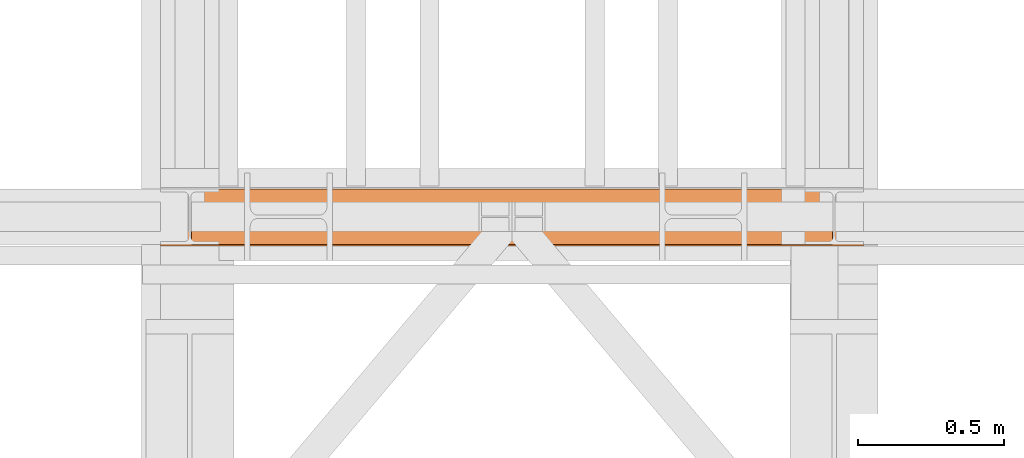
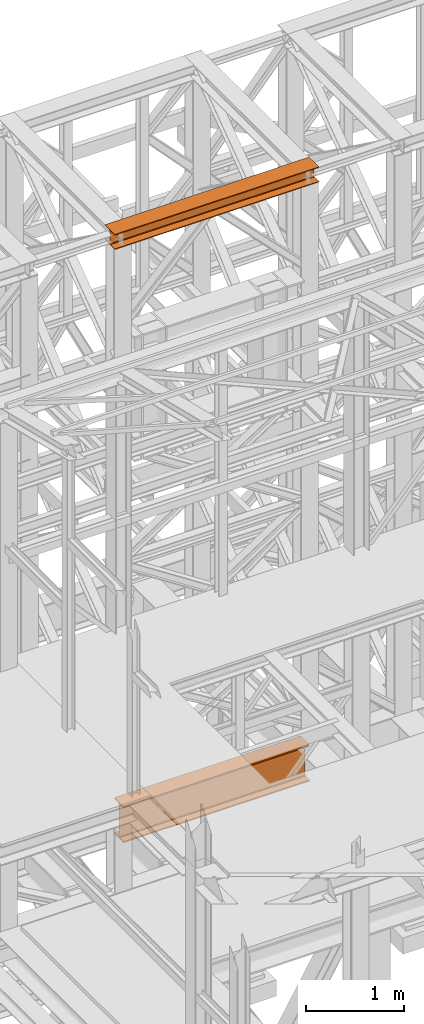
# One storey, part 145 of 208: 2 proxies.
"""IFC2X3 building model written with IfcOpenShell, lengths in millimetres."""

from ifc_helpers import new_model, entity, si_unit, converted_unit, frame, origin, origin_with_axes, place, context, subcontext, project, spatial, faceted_brep, element, save


model = new_model("IFC2X3")

# Units and contexts
model_context = context("Model", 3, precision=1e-05, world=origin())
plan_context = context("Plan", 3, precision=1e-05, world=origin())
body_context = subcontext(model_context, "Body", "Model", "MODEL_VIEW")
ifc_project = project(units=[si_unit("LENGTHUNIT", "METRE", prefix="MILLI"), converted_unit("PLANEANGLEUNIT", "DEGREE", entity("IfcPlaneAngleMeasure", 0.0174532925199433), si_unit("PLANEANGLEUNIT", "RADIAN"), dimensions=[0, 0, 0, 0, 0, 0, 0]), si_unit("AREAUNIT", "SQUARE_METRE"), si_unit("VOLUMEUNIT", "CUBIC_METRE")], contexts=[model_context, plan_context])

# Building, storey
building_placement = place(None, origin())
building = spatial("IfcBuilding", under=ifc_project, at=building_placement, CompositionType="COMPLEX")
storey_placement = place(building_placement, origin_with_axes())
storey = spatial("IfcBuildingStorey", under=building, at=storey_placement, Name="Geschoss", CompositionType="ELEMENT")

# Proxies
proxy_1_placement = place(storey_placement, frame((3299.254968580828, -16057.57439657637, 4834.989987483023), z_axis=(0.0, 0.0, 1.0), x_axis=(1.0, 0.0, 0.0)))
element("IfcBuildingElementProxy", 1, at=proxy_1_placement, inside=storey, context=body_context, shape_type="Brep", body=[
    faceted_brep([(2188.009999895692, 0.01000000000021828, 450.0100178813937), (2188.009999895692, 190.0100125169756, 450.0100178813937), (2188.009999895692, 190.0100125169756, 435.4100240564349), (2188.009999895692, 120.7100073045494, 435.4100091552737), (2188.009999895692, 109.841562265754, 433.2347078418734), (2188.009999895692, 101.8853126263621, 425.2784563398363), (2188.009999895692, 99.71000619068764, 414.4100113010409), (2188.009999895692, 99.71000619068764, 35.60999167919181), (2188.009999895692, 101.8853126263621, 24.74154664039634), (2188.009999895692, 109.841562265754, 16.78529513835929), (2188.009999895692, 120.7100073045494, 14.60999382495902), (2188.009999895692, 190.0100125169756, 14.60999382495902), (2188.009999895692, 190.0100125169756, 0.01000000000021828), (2188.009999895692, 0.01000000000021828, 0.01000000000021828), (2188.009999895692, 0.01000000000021828, 14.60999382495902), (2188.009999895692, 69.3100052124264, 14.60999382495902), (2188.009999895692, 80.17845025122188, 16.78529513835929), (2188.009999895692, 88.13469989061377, 24.74154664039634), (2188.009999895692, 90.3100063262882, 35.60999167919181), (2188.009999895692, 90.3100063262882, 414.4100113010409), (2188.009999895692, 88.13469989061377, 425.2784563398363), (2188.009999895692, 80.17845025122188, 433.2347078418734), (2188.009999895692, 69.3100052124264, 435.4100091552737), (2188.009999895692, 0.01000000000021828, 435.4100240564349), (2188.009999895692, 190.0100125169756, 450.0100178813937), (2188.009999895692, 0.01000000000021828, 450.0100178813937), (0.01000000000021828, 0.01000000000021828, 450.0100178813937), (0.01000000000021828, 190.0100125169756, 450.0100178813937), (2188.009999895692, 190.0100125169756, 435.4100240564349), (2188.009999895692, 190.0100125169756, 450.0100178813937), (0.01000000000021828, 190.0100125169756, 450.0100178813937), (0.01000000000021828, 190.0100125169756, 435.4100240564349), (2188.009999895692, 120.7100073045494, 435.4100091552737), (2188.009999895692, 190.0100125169756, 435.4100240564349), (0.01000000000021828, 190.0100125169756, 435.4100240564349), (0.01000000000021828, 120.7100073045494, 435.4100091552737), (2188.009999895692, 109.841562265754, 433.2347078418734), (2188.009999895692, 120.7100073045494, 435.4100091552737), (0.01000000000021828, 120.7100073045494, 435.4100091552737), (0.01000000000021828, 109.841562265754, 433.2347078418734), (2188.009999895692, 101.8853126263621, 425.2784563398363), (2188.009999895692, 109.841562265754, 433.2347078418734), (0.01000000000021828, 109.841562265754, 433.2347078418734), (0.01000000000021828, 101.8853126263621, 425.2784563398363), (2188.009999895692, 99.71000619068764, 414.4100113010409), (2188.009999895692, 101.8853126263621, 425.2784563398363), (0.01000000000021828, 101.8853126263621, 425.2784563398363), (0.01000000000021828, 99.71000619068764, 414.4100113010409), (2188.009999895692, 99.71000619068764, 35.60999167919181), (2188.009999895692, 99.71000619068764, 414.4100113010409), (0.01000000000021828, 99.71000619068764, 414.4100113010409), (0.01000000000021828, 99.71000619068764, 35.60999167919181), (2188.009999895692, 101.8853126263621, 24.74154664039634), (2188.009999895692, 99.71000619068764, 35.60999167919181), (0.01000000000021828, 99.71000619068764, 35.60999167919181), (0.01000000000021828, 101.8853126263621, 24.74154664039634), (2188.009999895692, 109.841562265754, 16.78529513835929), (2188.009999895692, 101.8853126263621, 24.74154664039634), (0.01000000000021828, 101.8853126263621, 24.74154664039634), (0.01000000000021828, 109.841562265754, 16.78529513835929), (2188.009999895692, 120.7100073045494, 14.60999382495902), (2188.009999895692, 109.841562265754, 16.78529513835929), (0.01000000000021828, 109.841562265754, 16.78529513835929), (0.01000000000021828, 120.7100073045494, 14.60999382495902), (2188.009999895692, 190.0100125169756, 14.60999382495902), (2188.009999895692, 120.7100073045494, 14.60999382495902), (0.01000000000021828, 120.7100073045494, 14.60999382495902), (0.01000000000021828, 190.0100125169756, 14.60999382495902), (2188.009999895692, 190.0100125169756, 0.01000000000021828), (2188.009999895692, 190.0100125169756, 14.60999382495902), (0.01000000000021828, 190.0100125169756, 14.60999382495902), (0.01000000000021828, 190.0100125169756, 0.01000000000021828), (2188.009999895692, 0.01000000000021828, 0.01000000000021828), (2188.009999895692, 190.0100125169756, 0.01000000000021828), (0.01000000000021828, 190.0100125169756, 0.01000000000021828), (0.01000000000021828, 0.01000000000021828, 0.01000000000021828), (2188.009999895692, 0.01000000000021828, 14.60999382495902), (2188.009999895692, 0.01000000000021828, 0.01000000000021828), (0.01000000000021828, 0.01000000000021828, 0.01000000000021828), (0.01000000000021828, 0.01000000000021828, 14.60999382495902), (2188.009999895692, 69.3100052124264, 14.60999382495902), (2188.009999895692, 0.01000000000021828, 14.60999382495902), (0.01000000000021828, 0.01000000000021828, 14.60999382495902), (0.01000000000021828, 69.3100052124264, 14.60999382495902), (2188.009999895692, 80.17845025122188, 16.78529513835929), (2188.009999895692, 69.3100052124264, 14.60999382495902), (0.01000000000021828, 69.3100052124264, 14.60999382495902), (0.01000000000021828, 80.17845025122188, 16.78529513835929), (2188.009999895692, 88.13469989061377, 24.74154664039634), (2188.009999895692, 80.17845025122188, 16.78529513835929), (0.01000000000021828, 80.17845025122188, 16.78529513835929), (0.01000000000021828, 88.13469989061377, 24.74154664039634), (2188.009999895692, 90.3100063262882, 35.60999167919181), (2188.009999895692, 88.13469989061377, 24.74154664039634), (0.01000000000021828, 88.13469989061377, 24.74154664039634), (0.01000000000021828, 90.3100063262882, 35.60999167919181), (2188.009999895692, 90.3100063262882, 414.4100113010409), (2188.009999895692, 90.3100063262882, 35.60999167919181), (0.01000000000021828, 90.3100063262882, 35.60999167919181), (0.01000000000021828, 90.3100063262882, 414.4100113010409), (2188.009999895692, 88.13469989061377, 425.2784563398363), (2188.009999895692, 90.3100063262882, 414.4100113010409), (0.01000000000021828, 90.3100063262882, 414.4100113010409), (0.01000000000021828, 88.13469989061377, 425.2784563398363), (2188.009999895692, 80.17845025122188, 433.2347078418734), (2188.009999895692, 88.13469989061377, 425.2784563398363), (0.01000000000021828, 88.13469989061377, 425.2784563398363), (0.01000000000021828, 80.17845025122188, 433.2347078418734), (2188.009999895692, 69.3100052124264, 435.4100091552737), (2188.009999895692, 80.17845025122188, 433.2347078418734), (0.01000000000021828, 80.17845025122188, 433.2347078418734), (0.01000000000021828, 69.3100052124264, 435.4100091552737), (2188.009999895692, 0.01000000000021828, 435.4100240564349), (2188.009999895692, 69.3100052124264, 435.4100091552737), (0.01000000000021828, 69.3100052124264, 435.4100091552737), (0.01000000000021828, 0.01000000000021828, 435.4100240564349), (2188.009999895692, 0.01000000000021828, 450.0100178813937), (2188.009999895692, 0.01000000000021828, 435.4100240564349), (0.01000000000021828, 0.01000000000021828, 435.4100240564349), (0.01000000000021828, 0.01000000000021828, 450.0100178813937), (0.01000000000021828, 0.01000000000021828, 450.0100178813937), (0.01000000000021828, 0.01000000000021828, 435.4100240564349), (0.01000000000021828, 69.3100052124264, 435.4100091552737), (0.01000000000021828, 80.17845025122188, 433.2347078418734), (0.01000000000021828, 88.13469989061377, 425.2784563398363), (0.01000000000021828, 90.3100063262882, 414.4100113010409), (0.01000000000021828, 90.3100063262882, 35.60999167919181), (0.01000000000021828, 88.13469989061377, 24.74154664039634), (0.01000000000021828, 80.17845025122188, 16.78529513835929), (0.01000000000021828, 69.3100052124264, 14.60999382495902), (0.01000000000021828, 0.01000000000021828, 14.60999382495902), (0.01000000000021828, 0.01000000000021828, 0.01000000000021828), (0.01000000000021828, 190.0100125169756, 0.01000000000021828), (0.01000000000021828, 190.0100125169756, 14.60999382495902), (0.01000000000021828, 120.7100073045494, 14.60999382495902), (0.01000000000021828, 109.841562265754, 16.78529513835929), (0.01000000000021828, 101.8853126263621, 24.74154664039634), (0.01000000000021828, 99.71000619068764, 35.60999167919181), (0.01000000000021828, 99.71000619068764, 414.4100113010409), (0.01000000000021828, 101.8853126263621, 425.2784563398363), (0.01000000000021828, 109.841562265754, 433.2347078418734), (0.01000000000021828, 120.7100073045494, 435.4100091552737), (0.01000000000021828, 190.0100125169756, 435.4100240564349), (0.01000000000021828, 190.0100125169756, 450.0100178813937)], [[[0, 1, 2, 3, 4, 5, 6, 7, 8, 9, 10, 11, 12, 13, 14, 15, 16, 17, 18, 19, 20, 21, 22, 23]], [[24, 25, 26, 27]], [[28, 29, 30, 31]], [[32, 33, 34, 35]], [[36, 37, 38, 39]], [[40, 41, 42, 43]], [[44, 45, 46, 47]], [[48, 49, 50, 51]], [[52, 53, 54, 55]], [[56, 57, 58, 59]], [[60, 61, 62, 63]], [[64, 65, 66, 67]], [[68, 69, 70, 71]], [[72, 73, 74, 75]], [[76, 77, 78, 79]], [[80, 81, 82, 83]], [[84, 85, 86, 87]], [[88, 89, 90, 91]], [[92, 93, 94, 95]], [[96, 97, 98, 99]], [[100, 101, 102, 103]], [[104, 105, 106, 107]], [[108, 109, 110, 111]], [[112, 113, 114, 115]], [[116, 117, 118, 119]], [[120, 121, 122, 123, 124, 125, 126, 127, 128, 129, 130, 131, 132, 133, 134, 135, 136, 137, 138, 139, 140, 141, 142, 143]]], orient=[[False], [False], [False], [False], [False], [False], [False], [False], [False], [False], [False], [False], [False], [False], [False], [False], [False], [False], [False], [False], [False], [False], [False], [False], [False], [False]]),
])
proxy_2_placement = place(storey_placement, frame((3193.254967038549, -16062.574391808, 12249.99005869381), z_axis=(0.0, 0.0, 1.0), x_axis=(1.0, 0.0, 0.0)))
element("IfcBuildingElementProxy", 2, at=proxy_2_placement, inside=storey, context=body_context, shape_type="Brep", body=[
    faceted_brep([(0.01000000000021828, 0.01000000000021828, 0.01000000000021828), (0.01000000000021828, 200.0100029802325, 0.01000000000021828), (0.01000000000021828, 200.0100029802325, 10.00999791383765), (0.01000000000021828, 121.2600035762789, 10.01000536441825), (0.01000000000021828, 111.9441915473344, 11.87455041170142), (0.01000000000021828, 105.1245498640838, 18.69419349193595), (0.01000000000021828, 103.2600015571716, 28.01000458955787), (0.01000000000021828, 103.2600015571716, 162.0100153779986), (0.01000000000021828, 105.1245498640838, 171.3258264756205), (0.01000000000021828, 111.9441915473344, 178.145469555855), (0.01000000000021828, 121.2600035762789, 180.0100146031382), (0.01000000000021828, 200.0100029802325, 180.0100146031382), (0.01000000000021828, 200.0100029802325, 190.0100125169756), (0.01000000000021828, 0.01000000000021828, 190.0100125169756), (0.01000000000021828, 0.01000000000021828, 180.0100146031382), (0.01000000000021828, 78.75999940395377, 180.0100146031382), (0.01000000000021828, 88.07581143289826, 178.145469555855), (0.01000000000021828, 94.89545311614893, 171.3258264756205), (0.01000000000021828, 96.76000142306111, 162.0100153779986), (0.01000000000021828, 96.76000142306111, 28.01000458955787), (0.01000000000021828, 94.89545311614893, 18.69419349193595), (0.01000000000021828, 88.07581143289826, 11.87455041170142), (0.01000000000021828, 78.75999940395377, 10.01000536441825), (0.01000000000021828, 0.01000000000021828, 10.00999791383765), (0.01000000000021828, 200.0100029802325, 0.01000000000021828), (0.01000000000021828, 0.01000000000021828, 0.01000000000021828), (2400.010002980233, 0.01000000000021828, 0.01000000000021828), (2400.010002980233, 200.0100029802325, 0.01000000000021828), (0.01000000000021828, 200.0100029802325, 10.00999791383765), (0.01000000000021828, 200.0100029802325, 0.01000000000021828), (2400.010002980233, 200.0100029802325, 0.01000000000021828), (2400.010002980233, 200.0100029802325, 10.00999791383765), (0.01000000000021828, 121.2600035762789, 10.01000536441825), (0.01000000000021828, 200.0100029802325, 10.00999791383765), (2400.010002980233, 200.0100029802325, 10.00999791383765), (2400.010002980233, 121.2600035762789, 10.01000536441825), (0.01000000000021828, 111.9441915473344, 11.87455041170142), (0.01000000000021828, 121.2600035762789, 10.01000536441825), (2400.010002980233, 121.2600035762789, 10.01000536441825), (2400.010002980233, 111.9441915473344, 11.87455041170142), (0.01000000000021828, 105.1245498640838, 18.69419349193595), (0.01000000000021828, 111.9441915473344, 11.87455041170142), (2400.010002980233, 111.9441915473344, 11.87455041170142), (2400.010002980233, 105.1245498640838, 18.69419349193595), (0.01000000000021828, 103.2600015571716, 28.01000458955787), (0.01000000000021828, 105.1245498640838, 18.69419349193595), (2400.010002980233, 105.1245498640838, 18.69419349193595), (2400.010002980233, 103.2600015571716, 28.01000458955787), (0.01000000000021828, 103.2600015571716, 162.0100153779986), (0.01000000000021828, 103.2600015571716, 28.01000458955787), (2400.010002980233, 103.2600015571716, 28.01000458955787), (2400.010002980233, 103.2600015571716, 162.0100153779986), (0.01000000000021828, 105.1245498640838, 171.3258264756205), (0.01000000000021828, 103.2600015571716, 162.0100153779986), (2400.010002980233, 103.2600015571716, 162.0100153779986), (2400.010002980233, 105.1245498640838, 171.3258264756205), (0.01000000000021828, 111.9441915473344, 178.145469555855), (0.01000000000021828, 105.1245498640838, 171.3258264756205), (2400.010002980233, 105.1245498640838, 171.3258264756205), (2400.010002980233, 111.9441915473344, 178.145469555855), (0.01000000000021828, 121.2600035762789, 180.0100146031382), (0.01000000000021828, 111.9441915473344, 178.145469555855), (2400.010002980233, 111.9441915473344, 178.145469555855), (2400.010002980233, 121.2600035762789, 180.0100146031382), (0.01000000000021828, 200.0100029802325, 180.0100146031382), (0.01000000000021828, 121.2600035762789, 180.0100146031382), (2400.010002980233, 121.2600035762789, 180.0100146031382), (2400.010002980233, 200.0100029802325, 180.0100146031382), (0.01000000000021828, 200.0100029802325, 190.0100125169756), (0.01000000000021828, 200.0100029802325, 180.0100146031382), (2400.010002980233, 200.0100029802325, 180.0100146031382), (2400.010002980233, 200.0100029802325, 190.0100125169756), (0.01000000000021828, 0.01000000000021828, 190.0100125169756), (0.01000000000021828, 200.0100029802325, 190.0100125169756), (2400.010002980233, 200.0100029802325, 190.0100125169756), (2400.010002980233, 0.01000000000021828, 190.0100125169756), (0.01000000000021828, 0.01000000000021828, 180.0100146031382), (0.01000000000021828, 0.01000000000021828, 190.0100125169756), (2400.010002980233, 0.01000000000021828, 190.0100125169756), (2400.010002980233, 0.01000000000021828, 180.0100146031382), (0.01000000000021828, 78.75999940395377, 180.0100146031382), (0.01000000000021828, 0.01000000000021828, 180.0100146031382), (2400.010002980233, 0.01000000000021828, 180.0100146031382), (2400.010002980233, 78.75999940395377, 180.0100146031382), (0.01000000000021828, 88.07581143289826, 178.145469555855), (0.01000000000021828, 78.75999940395377, 180.0100146031382), (2400.010002980233, 78.75999940395377, 180.0100146031382), (2400.010002980233, 88.07581143289826, 178.145469555855), (0.01000000000021828, 94.89545311614893, 171.3258264756205), (0.01000000000021828, 88.07581143289826, 178.145469555855), (2400.010002980233, 88.07581143289826, 178.145469555855), (2400.010002980233, 94.89545311614893, 171.3258264756205), (0.01000000000021828, 96.76000142306111, 162.0100153779986), (0.01000000000021828, 94.89545311614893, 171.3258264756205), (2400.010002980233, 94.89545311614893, 171.3258264756205), (2400.010002980233, 96.76000142306111, 162.0100153779986), (0.01000000000021828, 96.76000142306111, 28.01000458955787), (0.01000000000021828, 96.76000142306111, 162.0100153779986), (2400.010002980233, 96.76000142306111, 162.0100153779986), (2400.010002980233, 96.76000142306111, 28.01000458955787), (0.01000000000021828, 94.89545311614893, 18.69419349193595), (0.01000000000021828, 96.76000142306111, 28.01000458955787), (2400.010002980233, 96.76000142306111, 28.01000458955787), (2400.010002980233, 94.89545311614893, 18.69419349193595), (0.01000000000021828, 88.07581143289826, 11.87455041170142), (0.01000000000021828, 94.89545311614893, 18.69419349193595), (2400.010002980233, 94.89545311614893, 18.69419349193595), (2400.010002980233, 88.07581143289826, 11.87455041170142), (0.01000000000021828, 78.75999940395377, 10.01000536441825), (0.01000000000021828, 88.07581143289826, 11.87455041170142), (2400.010002980233, 88.07581143289826, 11.87455041170142), (2400.010002980233, 78.75999940395377, 10.01000536441825), (0.01000000000021828, 0.01000000000021828, 10.00999791383765), (0.01000000000021828, 78.75999940395377, 10.01000536441825), (2400.010002980233, 78.75999940395377, 10.01000536441825), (2400.010002980233, 0.01000000000021828, 10.00999791383765), (0.01000000000021828, 0.01000000000021828, 0.01000000000021828), (0.01000000000021828, 0.01000000000021828, 10.00999791383765), (2400.010002980233, 0.01000000000021828, 10.00999791383765), (2400.010002980233, 0.01000000000021828, 0.01000000000021828), (2400.010002980233, 0.01000000000021828, 0.01000000000021828), (2400.010002980233, 0.01000000000021828, 10.00999791383765), (2400.010002980233, 78.75999940395377, 10.01000536441825), (2400.010002980233, 88.07581143289826, 11.87455041170142), (2400.010002980233, 94.89545311614893, 18.69419349193595), (2400.010002980233, 96.76000142306111, 28.01000458955787), (2400.010002980233, 96.76000142306111, 162.0100153779986), (2400.010002980233, 94.89545311614893, 171.3258264756205), (2400.010002980233, 88.07581143289826, 178.145469555855), (2400.010002980233, 78.75999940395377, 180.0100146031382), (2400.010002980233, 0.01000000000021828, 180.0100146031382), (2400.010002980233, 0.01000000000021828, 190.0100125169756), (2400.010002980233, 200.0100029802325, 190.0100125169756), (2400.010002980233, 200.0100029802325, 180.0100146031382), (2400.010002980233, 121.2600035762789, 180.0100146031382), (2400.010002980233, 111.9441915473344, 178.145469555855), (2400.010002980233, 105.1245498640838, 171.3258264756205), (2400.010002980233, 103.2600015571716, 162.0100153779986), (2400.010002980233, 103.2600015571716, 28.01000458955787), (2400.010002980233, 105.1245498640838, 18.69419349193595), (2400.010002980233, 111.9441915473344, 11.87455041170142), (2400.010002980233, 121.2600035762789, 10.01000536441825), (2400.010002980233, 200.0100029802325, 10.00999791383765), (2400.010002980233, 200.0100029802325, 0.01000000000021828)], [[[0, 1, 2, 3, 4, 5, 6, 7, 8, 9, 10, 11, 12, 13, 14, 15, 16, 17, 18, 19, 20, 21, 22, 23]], [[24, 25, 26, 27]], [[28, 29, 30, 31]], [[32, 33, 34, 35]], [[36, 37, 38, 39]], [[40, 41, 42, 43]], [[44, 45, 46, 47]], [[48, 49, 50, 51]], [[52, 53, 54, 55]], [[56, 57, 58, 59]], [[60, 61, 62, 63]], [[64, 65, 66, 67]], [[68, 69, 70, 71]], [[72, 73, 74, 75]], [[76, 77, 78, 79]], [[80, 81, 82, 83]], [[84, 85, 86, 87]], [[88, 89, 90, 91]], [[92, 93, 94, 95]], [[96, 97, 98, 99]], [[100, 101, 102, 103]], [[104, 105, 106, 107]], [[108, 109, 110, 111]], [[112, 113, 114, 115]], [[116, 117, 118, 119]], [[120, 121, 122, 123, 124, 125, 126, 127, 128, 129, 130, 131, 132, 133, 134, 135, 136, 137, 138, 139, 140, 141, 142, 143]]], orient=[[False], [False], [False], [False], [False], [False], [False], [False], [False], [False], [False], [False], [False], [False], [False], [False], [False], [False], [False], [False], [False], [False], [False], [False], [False], [False]]),
])

save(model, "model.ifc")
